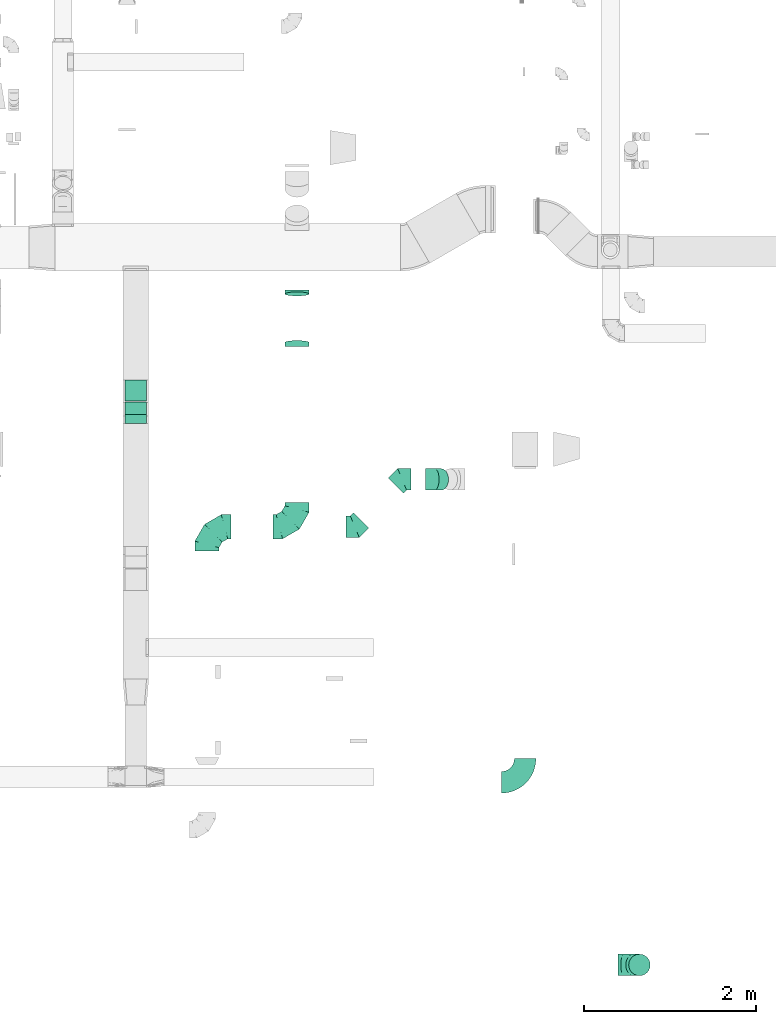
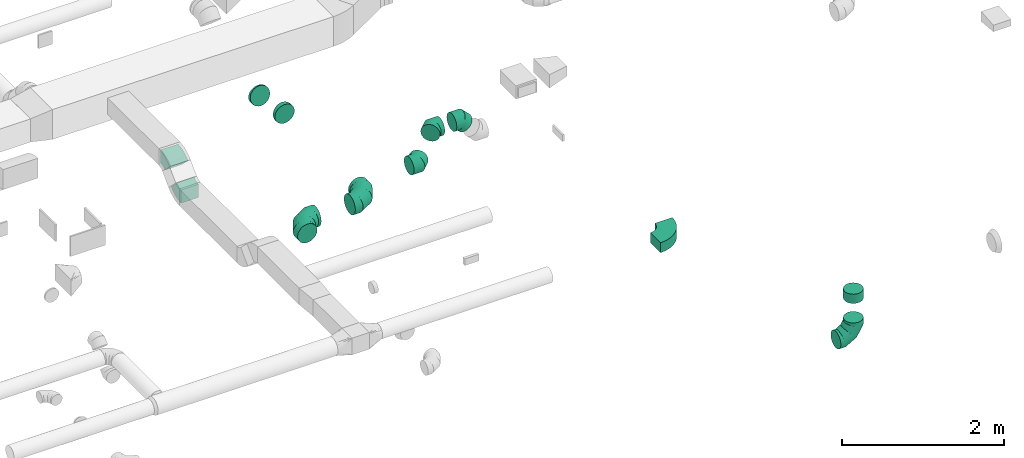
# One storey, part 39 of 62: 12 flow fittings.
"""IFC2X3 building model written with IfcOpenShell, lengths in millimetres."""

import ifcopenshell
import ifcopenshell.guid

model = None  # the IFC model being written
_history = None  # IfcOwnerHistory: only IFC2X3 demands one
_inside = {}  # id of a spatial element -> (the spatial element, [elements in it])
_under = {}  # id of a project, library or spatial element -> (it, [spatial elements below it])
_declared = {}  # id of a project -> (the project, [libraries it declares])
_typed = {}  # id of a type object -> (the type object, [elements of that type])
_made_of = {}  # id of a material, layer set ... -> (it, [elements and type objects made of it])


def new_model(schema):
    """Start an empty IFC model of exactly this schema.

    Asked for "IFC4X3", IfcOpenShell would pick the latest addendum, in which some entities
    have other attributes; the version numbers below select the first issue.
    IFC2X3 requires an IfcOwnerHistory on every rooted entity: one is made here for all.
    """
    global model, _history
    if schema == "IFC4X3":
        model = ifcopenshell.file(schema_version=(4, 3, 0, 0))
    else:
        model = ifcopenshell.file(schema=schema)
    _inside.clear()
    _under.clear()
    _declared.clear()
    _typed.clear()
    _made_of.clear()
    _history = None
    if model.schema == "IFC2X3":
        org = make("IfcOrganization", Name="unknown")
        user = make(
            "IfcPersonAndOrganization",
            ThePerson=make("IfcPerson", FamilyName="unknown"),
            TheOrganization=org,
        )
        app = make(
            "IfcApplication",
            ApplicationDeveloper=org,
            Version="unknown",
            ApplicationFullName="unknown",
            ApplicationIdentifier="unknown",
        )
        _history = make(
            "IfcOwnerHistory",
            OwningUser=user,
            OwningApplication=app,
            ChangeAction="ADDED",
            CreationDate=0,
        )
    return model


def make(cls, **values):
    """One entity of the class cls with the attributes given. An attribute that is None is left unset."""
    return model.create_entity(
        cls, **{name: value for name, value in values.items() if value is not None}
    )


def entity(cls, *values):
    """Any entity or typed value of the class cls, its attributes in the order of the schema. None: left unset."""
    e = model.create_entity(cls)
    for i, value in enumerate(values):
        if value is not None:
            e[i] = value
    return e


def rooted(cls, **values):
    """An entity with a GlobalId (a new one), such as an element, a storey or a relation."""
    return make(cls, GlobalId=ifcopenshell.guid.new(), OwnerHistory=_history, **values)


def si_unit(unit_type, name, prefix=None):
    """IfcSIUnit, for example si_unit("LENGTHUNIT", "METRE", prefix="MILLI")."""
    return make("IfcSIUnit", UnitType=unit_type, Prefix=prefix, Name=name)


def converted_unit(unit_type, name, factor, base, dimensions=None, offset=None):
    """IfcConversionBasedUnit, such as the inch: factor (a typed value) times the base unit."""
    return make(
        "IfcConversionBasedUnit"
        if offset is None
        else "IfcConversionBasedUnitWithOffset",
        ConversionOffset=offset,
        Dimensions=None
        if dimensions is None
        else entity("IfcDimensionalExponents", *dimensions),
        UnitType=unit_type,
        Name=name,
        ConversionFactor=make(
            "IfcMeasureWithUnit", ValueComponent=factor, UnitComponent=base
        ),
    )


def derived_unit(unit_type, elements):
    """IfcDerivedUnit: a product of units, each with its exponent."""
    return make(
        "IfcDerivedUnit",
        Elements=[
            make("IfcDerivedUnitElement", Unit=unit, Exponent=power)
            for unit, power in elements
        ],
        UnitType=unit_type,
    )


def assignment(units):
    """IfcUnitAssignment: the units of a project."""
    return None if units is None else make("IfcUnitAssignment", Units=units)


def point(xyz):
    """IfcCartesianPoint."""
    return None if xyz is None else make("IfcCartesianPoint", Coordinates=xyz)


def direction(xyz):
    """IfcDirection."""
    return None if xyz is None else make("IfcDirection", DirectionRatios=xyz)


def frame(location, z_axis=None, x_axis=None):
    """IfcAxis2Placement3D, a coordinate frame: its origin and axes. An axis left out is left unset."""
    return make(
        "IfcAxis2Placement3D",
        Location=point(location),
        Axis=direction(z_axis),
        RefDirection=direction(x_axis),
    )


def frame_2d(location, x_axis=None):
    """IfcAxis2Placement2D, a coordinate frame in the plane: its origin and x axis."""
    return make(
        "IfcAxis2Placement2D", Location=point(location), RefDirection=direction(x_axis)
    )


def origin():
    """The frame at (0, 0, 0) with its axes left unset."""
    return frame((0.0, 0.0, 0.0))


def place(relative_to, where):
    """IfcLocalPlacement: puts the frame where relative to a parent placement (None: the world)."""
    return make(
        "IfcLocalPlacement", PlacementRelTo=relative_to, RelativePlacement=where
    )


def context(
    kind, dimensions, precision=None, world=None, true_north=None, identifier=None
):
    """IfcGeometricRepresentationContext, for example the 3D "Model" context."""
    return make(
        "IfcGeometricRepresentationContext",
        ContextIdentifier=identifier,
        ContextType=kind,
        CoordinateSpaceDimension=dimensions,
        Precision=precision,
        WorldCoordinateSystem=world,
        TrueNorth=true_north,
    )


def subcontext(parent, identifier, kind, view, scale=None):
    """IfcGeometricRepresentationSubContext, for example "Body" below "Model"."""
    return make(
        "IfcGeometricRepresentationSubContext",
        ContextIdentifier=identifier,
        ContextType=kind,
        ParentContext=parent,
        TargetScale=scale,
        TargetView=view,
    )


def project(units=None, contexts=None):
    """IfcProject with its units and contexts."""
    return rooted(
        "IfcProject",
        Name="project",
        RepresentationContexts=contexts,
        UnitsInContext=assignment(units),
    )


def spatial(cls, under=None, at=None, **own):
    """A site, building, storey or space (cls), placed at a placement, below another one or the project."""
    s = rooted(cls, ObjectPlacement=at, **own)
    if under is not None:
        _under.setdefault(under.id(), (under, []))[1].append(s)
    return s


def polyline(points):
    """IfcPolyline through the points."""
    return make("IfcPolyline", Points=[point(p) for p in points])


def circle_curve(where, radius):
    """IfcCircle in the frame where."""
    return make("IfcCircle", Position=where, Radius=radius)


def parameter(value):
    """IfcParameterValue: where a trimmed curve begins or ends, as a parameter of its basis curve."""
    return model.create_entity("IfcParameterValue", value)


def trimmed(basis, trim1, trim2, sense, master):
    """IfcTrimmedCurve: the piece of a basis curve between two trims."""
    return make(
        "IfcTrimmedCurve",
        BasisCurve=basis,
        Trim1=trim1,
        Trim2=trim2,
        SenseAgreement=sense,
        MasterRepresentation=master,
    )


def segment(curve, same_sense, transition):
    """IfcCompositeCurveSegment."""
    return make(
        "IfcCompositeCurveSegment",
        Transition=transition,
        SameSense=same_sense,
        ParentCurve=curve,
    )


def composite_curve(segments, self_intersect=None):
    """IfcCompositeCurve: segments joined end to end."""
    return make("IfcCompositeCurve", Segments=segments, SelfIntersect=self_intersect)


def outline(outer, holes=None, kind="AREA"):
    """IfcArbitraryClosedProfileDef: a profile drawn as a closed curve; with holes, ...WithVoids."""
    if holes is None:
        return make("IfcArbitraryClosedProfileDef", ProfileType=kind, OuterCurve=outer)
    return make(
        "IfcArbitraryProfileDefWithVoids",
        ProfileType=kind,
        OuterCurve=outer,
        InnerCurves=holes,
    )


def extrude(swept, where, along, depth):
    """IfcExtrudedAreaSolid: the profile swept, set in the frame where, extruded along a direction by depth."""
    return make(
        "IfcExtrudedAreaSolid",
        SweptArea=swept,
        Position=where,
        ExtrudedDirection=direction(along),
        Depth=depth,
    )


def faces_of(points, faces, orient=None, outer=None):
    """IfcFace entities. A face is a list of loops; a loop is a list of indices into points, from 0.

    orient and outer hold one flag for each loop. By default every Orientation is true, the
    first loop of a face is its IfcFaceOuterBound and the others are IfcFaceBound.
    """
    made = []
    for i, loops in enumerate(faces):
        bounds = []
        for j, loop in enumerate(loops):
            is_outer = j == 0 if outer is None else outer[i][j]
            bounds.append(
                make(
                    "IfcFaceOuterBound" if is_outer else "IfcFaceBound",
                    Bound=make("IfcPolyLoop", Polygon=[points[k] for k in loop]),
                    Orientation=True if orient is None else orient[i][j],
                )
            )
        made.append(make("IfcFace", Bounds=bounds))
    return made


def faceted_brep(points, faces, orient=None, outer=None, voids=None):
    """IfcFacetedBrep: a solid bounded by flat faces; with voids (closed shells), ...WithVoids."""
    shared = [point(p) for p in points]
    hull = make("IfcClosedShell", CfsFaces=faces_of(shared, faces, orient, outer))
    if voids is None:
        return make("IfcFacetedBrep", Outer=hull)
    return make(
        "IfcFacetedBrepWithVoids",
        Outer=hull,
        Voids=[
            make(cls, CfsFaces=faces_of(shared, fs, o, b)) for cls, fs, o, b in voids
        ],
    )


def shape(context_of_items, identifier, shape_type, items):
    """IfcShapeRepresentation: the items that make up one representation, for example the "Body"."""
    return make(
        "IfcShapeRepresentation",
        ContextOfItems=context_of_items,
        RepresentationIdentifier=identifier,
        RepresentationType=shape_type,
        Items=items,
    )


def source(mapping_origin, context_of_items, identifier, shape_type, items):
    """IfcRepresentationMap: a shape defined once, which mapped items show again and again."""
    return make(
        "IfcRepresentationMap",
        MappingOrigin=mapping_origin,
        MappedRepresentation=shape(context_of_items, identifier, shape_type, items),
    )


def transform(
    local_origin,
    x_axis=None,
    y_axis=None,
    z_axis=None,
    scale=None,
    scale2=None,
    scale3=None,
    uniform=True,
):
    """IfcCartesianTransformationOperator3D, or its non-uniform kind. x_axis, y_axis, z_axis: its Axis1, 2, 3."""
    if uniform:
        return make(
            "IfcCartesianTransformationOperator3D",
            Axis1=direction(x_axis),
            Axis2=direction(y_axis),
            LocalOrigin=point(local_origin),
            Scale=scale,
            Axis3=direction(z_axis),
        )
    return make(
        "IfcCartesianTransformationOperator3DnonUniform",
        Axis1=direction(x_axis),
        Axis2=direction(y_axis),
        LocalOrigin=point(local_origin),
        Scale=scale,
        Axis3=direction(z_axis),
        Scale2=scale2,
        Scale3=scale3,
    )


def mapped(mapping_source, mapping_target):
    """IfcMappedItem: shows the shape of a source again, moved by a transform."""
    return make(
        "IfcMappedItem", MappingSource=mapping_source, MappingTarget=mapping_target
    )


def material(Name=None, Category=None):
    """IfcMaterial."""
    return make("IfcMaterial", Name=Name, Category=Category)


def made_of(thing, what):
    """Note that an element or type object is made of a material, layer set ...; save() writes the relation."""
    if what is not None:
        _made_of.setdefault(what.id(), (what, []))[1].append(thing)
    return thing


def type_object(cls, material=None, **own):
    """A type object (cls), such as IfcWallType, which elements share."""
    return made_of(rooted(cls, **own), material)


def type_shapes(of_type, sources):
    """Give a type object the sources (RepresentationMaps) that its elements show as mapped items."""
    of_type.RepresentationMaps = sources


def element(
    cls,
    number,
    at=None,
    inside=None,
    cuts=None,
    type_object=None,
    material=None,
    context=None,
    identifier="Body",
    shape_type=None,
    held_by="IfcProductDefinitionShape",
    body=None,
    shapes=None,
    **own,
):
    """One element of the class cls, such as IfcWall. Its Tag is "e" and its number.

    at: its placement. inside: the storey or other place that contains it. cuts: it is an
    opening in that element (IfcRelVoidsElement). A single representation is given by context,
    identifier, shape_type and body (its items); several are given by shapes. held_by: the class
    of the entity that holds the representations. save() writes the other relations.
    """
    e = rooted(cls, Tag="e%d" % number, ObjectPlacement=at, **own)
    if body is not None:
        shapes = [shape(context, identifier, shape_type, body)]
    if shapes is not None:
        e.Representation = make(held_by, Representations=shapes)
    if inside is not None:
        _inside.setdefault(inside.id(), (inside, []))[1].append(e)
    if cuts is not None:
        rooted(
            "IfcRelVoidsElement", RelatingBuildingElement=cuts, RelatedOpeningElement=e
        )
    if type_object is not None:
        _typed.setdefault(type_object.id(), (type_object, []))[1].append(e)
    return made_of(e, material)


def aggregate(whole, parts):
    """IfcRelAggregates: a whole, such as a stair, and the parts it consists of."""
    return rooted("IfcRelAggregates", RelatingObject=whole, RelatedObjects=parts)


def save(model, path):
    """Write the relations noted so far, then the file.

    IfcRelAggregates (storeys below a building ...), IfcRelContainedInSpatialStructure (elements
    in a storey), IfcRelDefinesByType, IfcRelAssociatesMaterial and IfcRelDeclares: one each for
    every whole, place, type object, material and project.
    """
    for whole, parts in _under.values():
        aggregate(whole, parts)
    for where, things in _inside.values():
        rooted(
            "IfcRelContainedInSpatialStructure",
            RelatedElements=things,
            RelatingStructure=where,
        )
    for kind, things in _typed.values():
        rooted("IfcRelDefinesByType", RelatedObjects=things, RelatingType=kind)
    for what, things in _made_of.values():
        rooted("IfcRelAssociatesMaterial", RelatedObjects=things, RelatingMaterial=what)
    for by, libraries in _declared.values():
        rooted("IfcRelDeclares", RelatingContext=by, RelatedDefinitions=libraries)
    model.write(path)


model = new_model("IFC2X3")

# Units and contexts
model_context = context("Model", 3, precision=0.01, world=origin(), true_north=direction((6.12303176911189e-17, 1.0)))
body_context = subcontext(model_context, "Body", "Model", "MODEL_VIEW")
ifc_project = project(units=[si_unit("LENGTHUNIT", "METRE", prefix="MILLI"), si_unit("AREAUNIT", "SQUARE_METRE"), si_unit("VOLUMEUNIT", "CUBIC_METRE"), converted_unit("PLANEANGLEUNIT", "DEGREE", entity("IfcRatioMeasure", 0.0174532925199433), si_unit("PLANEANGLEUNIT", "RADIAN"), dimensions=[0, 0, 0, 0, 0, 0, 0]), si_unit("MASSUNIT", "GRAM", prefix="KILO"), derived_unit("MASSDENSITYUNIT", [(si_unit("MASSUNIT", "GRAM", prefix="KILO"), 1), (si_unit("LENGTHUNIT", "METRE"), -3)]), derived_unit("MOMENTOFINERTIAUNIT", [(si_unit("LENGTHUNIT", "METRE"), 4)]), si_unit("TIMEUNIT", "SECOND"), si_unit("FREQUENCYUNIT", "HERTZ"), si_unit("THERMODYNAMICTEMPERATUREUNIT", "DEGREE_CELSIUS"), derived_unit("THERMALTRANSMITTANCEUNIT", [(si_unit("MASSUNIT", "GRAM", prefix="KILO"), 1), (si_unit("THERMODYNAMICTEMPERATUREUNIT", "KELVIN"), -1), (si_unit("TIMEUNIT", "SECOND"), -3)]), derived_unit("VOLUMETRICFLOWRATEUNIT", [(si_unit("LENGTHUNIT", "METRE"), 3), (si_unit("TIMEUNIT", "SECOND"), -1)]), derived_unit("MASSFLOWRATEUNIT", [(si_unit("MASSUNIT", "GRAM", prefix="KILO"), 1), (si_unit("TIMEUNIT", "SECOND"), -1)]), derived_unit("ROTATIONALFREQUENCYUNIT", [(si_unit("TIMEUNIT", "SECOND"), -1)]), si_unit("ELECTRICCURRENTUNIT", "AMPERE"), si_unit("ELECTRICVOLTAGEUNIT", "VOLT"), si_unit("POWERUNIT", "WATT"), si_unit("FORCEUNIT", "NEWTON", prefix="KILO"), si_unit("ILLUMINANCEUNIT", "LUX"), si_unit("LUMINOUSFLUXUNIT", "LUMEN"), si_unit("LUMINOUSINTENSITYUNIT", "CANDELA"), derived_unit("USERDEFINED", [(si_unit("MASSUNIT", "GRAM", prefix="KILO"), -1), (si_unit("LENGTHUNIT", "METRE"), -2), (si_unit("TIMEUNIT", "SECOND"), 3), (si_unit("LUMINOUSFLUXUNIT", "LUMEN"), 1)]), derived_unit("LINEARVELOCITYUNIT", [(si_unit("LENGTHUNIT", "METRE"), 1), (si_unit("TIMEUNIT", "SECOND"), -1)]), si_unit("PRESSUREUNIT", "PASCAL"), derived_unit("USERDEFINED", [(si_unit("LENGTHUNIT", "METRE"), -2), (si_unit("MASSUNIT", "GRAM", prefix="KILO"), 1), (si_unit("TIMEUNIT", "SECOND"), -2)]), derived_unit("LINEARFORCEUNIT", [(si_unit("MASSUNIT", "GRAM", prefix="KILO"), 1), (si_unit("LENGTHUNIT", "METRE"), 1), (si_unit("TIMEUNIT", "SECOND"), -2), (si_unit("LENGTHUNIT", "METRE"), -1)]), derived_unit("PLANARFORCEUNIT", [(si_unit("MASSUNIT", "GRAM", prefix="KILO"), 1), (si_unit("LENGTHUNIT", "METRE"), 1), (si_unit("TIMEUNIT", "SECOND"), -2), (si_unit("LENGTHUNIT", "METRE"), -2)])], contexts=[model_context])

# Site, building, storey
site_placement = place(None, origin())
site = spatial("IfcSite", under=ifc_project, at=site_placement, CompositionType="ELEMENT")
building_placement = place(site_placement, origin())
building = spatial("IfcBuilding", under=site, at=building_placement, CompositionType="ELEMENT")
storey_placement = place(building_placement, frame((0.0, 0.0, 24000.0)))
storey = spatial("IfcBuildingStorey", under=building, at=storey_placement, CompositionType="ELEMENT", Elevation=24000.0)

# Flow fittings
ifc_material = material()
duct_fitting_type_1 = type_object("IfcDuctFittingType", PredefinedType="NOTDEFINED", material=ifc_material)
shared_shape_1 = source(origin(), body_context, "Body", "Brep", [
    faceted_brep([(-250.0, 0.0, -125.0), (-250.0, -32.35, -120.74), (-250.0, -62.5, -108.25), (-250.0, -88.39, -88.39), (-250.0, -108.25, -62.5), (-250.0, -120.74, -32.35), (-250.0, -125.0, 0.0), (-250.0, -120.74, 32.35), (-250.0, -108.25, 62.5), (-250.0, -88.39, 88.39), (-250.0, -62.5, 108.25), (-250.0, -32.35, 120.74), (-250.0, 0.0, 125.0), (-250.0, 32.35, 120.74), (-250.0, 62.5, 108.25), (-250.0, 88.39, 88.39), (-250.0, 108.25, 62.5), (-250.0, 120.74, 32.35), (-250.0, 125.0, 0.0), (-250.0, 120.74, -32.35), (-250.0, 108.25, -62.5), (-250.0, 88.39, -88.39), (-250.0, 62.5, -108.25), (-250.0, 32.35, -120.74), (-191.68, 32.35, 120.74), (-199.76, 62.5, 108.25), (-183.01, 0.0, 125.0), (-206.7, 88.39, 88.39), (-215.37, 120.74, 32.35), (-216.51, 125.0, 0.0), (-212.02, 108.25, 62.5), (-212.02, 108.25, -62.5), (-206.7, 88.39, -88.39), (-215.37, 120.74, -32.35), (-191.68, 32.35, -120.74), (-183.01, 0.0, -125.0), (-199.76, 62.5, -108.25), (-174.34, -32.35, -120.74), (-166.27, -62.5, -108.25), (-159.33, -88.39, -88.39), (-154.01, -108.25, -62.5), (-150.66, -120.74, -32.35), (-149.52, -125.0, 0.0), (-150.66, -120.74, 32.35), (-154.01, -108.25, 62.5), (-159.33, -88.39, 88.39), (-166.27, -62.5, 108.25), (-174.34, -32.35, 120.74), (-90.67, 90.67, 120.74), (-112.74, 112.74, 108.25), (-66.99, 66.99, 125.0), (-131.69, 131.69, 88.39), (-146.23, 146.23, 62.5), (-155.38, 155.38, 32.35), (-158.49, 158.49, 0.0), (-155.38, 155.38, -32.35), (-146.23, 146.23, -62.5), (-131.69, 131.69, -88.39), (-90.67, 90.67, -120.74), (-66.99, 66.99, -125.0), (-112.74, 112.74, -108.25), (-43.3, 43.3, -120.74), (-21.23, 21.23, -108.25), (-2.28, 2.28, -88.39), (12.26, -12.26, -62.5), (21.4, -21.4, -32.35), (24.52, -24.52, 0.0), (21.4, -21.4, 32.35), (12.26, -12.26, 62.5), (-2.28, 2.28, 88.39), (-21.23, 21.23, 108.25), (-43.3, 43.3, 120.74), (-32.35, 191.68, 120.74), (-62.5, 199.76, 108.25), (0.0, 183.01, 125.0), (-88.39, 206.7, 88.39), (-108.25, 212.02, 62.5), (-120.74, 215.37, 32.35), (-125.0, 216.51, 0.0), (-120.74, 215.37, -32.35), (-108.25, 212.02, -62.5), (-88.39, 206.7, -88.39), (-32.35, 191.68, -120.74), (0.0, 183.01, -125.0), (-62.5, 199.76, -108.25), (32.35, 174.34, -120.74), (62.5, 166.27, -108.25), (88.39, 159.33, -88.39), (108.25, 154.01, -62.5), (120.74, 150.66, -32.35), (125.0, 149.52, 0.0), (120.74, 150.66, 32.35), (108.25, 154.01, 62.5), (88.39, 159.33, 88.39), (62.5, 166.27, 108.25), (32.35, 174.34, 120.74), (-32.35, 250.0, -120.74), (-62.5, 250.0, -108.25), (-88.39, 250.0, -88.39), (-108.25, 250.0, -62.5), (-120.74, 250.0, -32.35), (-125.0, 250.0, 0.0), (-120.74, 250.0, 32.35), (-108.25, 250.0, 62.5), (-88.39, 250.0, 88.39), (-62.5, 250.0, 108.25), (-32.35, 250.0, 120.74), (0.0, 250.0, 125.0), (32.35, 250.0, 120.74), (62.5, 250.0, 108.25), (88.39, 250.0, 88.39), (108.25, 250.0, 62.5), (120.74, 250.0, 32.35), (125.0, 250.0, 0.0), (120.74, 250.0, -32.35), (108.25, 250.0, -62.5), (88.39, 250.0, -88.39), (62.5, 250.0, -108.25), (32.35, 250.0, -120.74), (0.0, 250.0, -125.0)], [[[0, 1, 2, 3, 4, 5, 6, 7, 8, 9, 10, 11, 12, 13, 14, 15, 16, 17, 18, 19, 20, 21, 22, 23]], [[24, 25, 14, 13]], [[26, 24, 13, 12]], [[14, 25, 27, 15]], [[28, 29, 18, 17]], [[30, 28, 17, 16]], [[15, 27, 30, 16]], [[20, 31, 32, 21]], [[33, 31, 20, 19]], [[18, 29, 33, 19]], [[34, 35, 0, 23]], [[36, 34, 23, 22]], [[21, 32, 36, 22]], [[1, 0, 35, 37]], [[2, 1, 37, 38]], [[38, 39, 3, 2]], [[5, 4, 40, 41]], [[6, 5, 41, 42]], [[39, 40, 4, 3]], [[6, 42, 43, 7]], [[7, 43, 44, 8]], [[8, 44, 45, 9]], [[9, 45, 46, 10]], [[10, 46, 47, 11]], [[26, 12, 11, 47]], [[48, 49, 25, 24]], [[50, 48, 24, 26]], [[27, 25, 49, 51]], [[52, 53, 28, 30]], [[51, 52, 30, 27]], [[29, 28, 53, 54]], [[55, 56, 31, 33]], [[54, 55, 33, 29]], [[32, 31, 56, 57]], [[58, 59, 35, 34]], [[60, 58, 34, 36]], [[57, 60, 36, 32]], [[37, 35, 59, 61]], [[38, 37, 61, 62]], [[39, 38, 62, 63]], [[41, 40, 64, 65]], [[42, 41, 65, 66]], [[63, 64, 40, 39]], [[43, 42, 66, 67]], [[44, 43, 67, 68]], [[68, 69, 45, 44]], [[46, 45, 69, 70]], [[47, 46, 70, 71]], [[26, 47, 71, 50]], [[72, 73, 49, 48]], [[74, 72, 48, 50]], [[51, 49, 73, 75]], [[76, 77, 53, 52]], [[75, 76, 52, 51]], [[54, 53, 77, 78]], [[79, 80, 56, 55]], [[78, 79, 55, 54]], [[57, 56, 80, 81]], [[82, 83, 59, 58]], [[84, 82, 58, 60]], [[81, 84, 60, 57]], [[61, 59, 83, 85]], [[62, 61, 85, 86]], [[63, 62, 86, 87]], [[65, 64, 88, 89]], [[66, 65, 89, 90]], [[87, 88, 64, 63]], [[67, 66, 90, 91]], [[68, 67, 91, 92]], [[92, 93, 69, 68]], [[70, 69, 93, 94]], [[71, 70, 94, 95]], [[50, 71, 95, 74]], [[96, 97, 98, 99, 100, 101, 102, 103, 104, 105, 106, 107, 108, 109, 110, 111, 112, 113, 114, 115, 116, 117, 118, 119]], [[72, 74, 107, 106]], [[73, 72, 106, 105]], [[75, 73, 105, 104]], [[77, 76, 103, 102]], [[78, 77, 102, 101]], [[75, 104, 103, 76]], [[78, 101, 100, 79]], [[79, 100, 99, 80]], [[80, 99, 98, 81]], [[84, 97, 96, 82]], [[82, 96, 119, 83]], [[84, 81, 98, 97]], [[83, 119, 118, 85]], [[85, 118, 117, 86]], [[116, 87, 86, 117]], [[88, 115, 114, 89]], [[89, 114, 113, 90]], [[115, 88, 87, 116]], [[91, 90, 113, 112]], [[92, 91, 112, 111]], [[111, 110, 93, 92]], [[95, 94, 109, 108]], [[74, 95, 108, 107]], [[110, 109, 94, 93]]]),
])
type_shapes(duct_fitting_type_1, [shared_shape_1])
flow_fitting_1_placement = place(storey_placement, frame((61027.3, 593.17, 2900.0), z_axis=(0.0, -1.0, 0.0), x_axis=(1.0, 0.0, 0.0)))
element("IfcFlowFitting", 1, at=flow_fitting_1_placement, inside=storey, type_object=duct_fitting_type_1, material=ifc_material, context=body_context, shape_type="MappedRepresentation", body=[
    mapped(shared_shape_1, transform((0.0, 0.0, 0.0), scale=1.0)),
])
duct_fitting_type_2 = type_object("IfcDuctFittingType", PredefinedType="NOTDEFINED", material=ifc_material)
shared_shape_2 = source(origin(), body_context, "Body", "Brep", [
    faceted_brep([(-103.55, 0.0, -125.0), (-103.55, -32.35, -120.74), (-103.55, -62.5, -108.25), (-103.55, -88.39, -88.39), (-103.55, -108.25, -62.5), (-103.55, -120.74, -32.35), (-103.55, -125.0, 0.0), (-103.55, -120.74, 32.35), (-103.55, -108.25, 62.5), (-103.55, -88.39, 88.39), (-103.55, -62.5, 108.25), (-103.55, -32.35, 120.74), (-103.55, 0.0, 125.0), (-103.55, 32.35, 120.74), (-103.55, 62.5, 108.25), (-103.55, 88.39, 88.39), (-103.55, 108.25, 62.5), (-103.55, 120.74, 32.35), (-103.55, 125.0, 0.0), (-103.55, 120.74, -32.35), (-103.55, 108.25, -62.5), (-103.55, 88.39, -88.39), (-103.55, 62.5, -108.25), (-103.55, 32.35, -120.74), (-13.4, 32.35, 120.74), (-25.89, 62.5, 108.25), (0.0, 0.0, 125.0), (-36.61, 88.39, 88.39), (-44.84, 108.25, 62.5), (-50.01, 120.74, 32.35), (-51.78, 125.0, 0.0), (-50.01, 120.74, -32.35), (-44.84, 108.25, -62.5), (-36.61, 88.39, -88.39), (-13.4, 32.35, -120.74), (0.0, 0.0, -125.0), (-25.89, 62.5, -108.25), (13.4, -32.35, -120.74), (25.89, -62.5, -108.25), (36.61, -88.39, -88.39), (44.84, -108.25, -62.5), (50.01, -120.74, -32.35), (51.78, -125.0, 0.0), (50.01, -120.74, 32.35), (44.84, -108.25, 62.5), (36.61, -88.39, 88.39), (25.89, -62.5, 108.25), (13.4, -32.35, 120.74), (73.22, 73.22, 125.0), (50.35, 96.1, 120.74), (29.03, 117.42, 108.25), (10.72, 135.72, 88.39), (-3.32, 149.77, 62.5), (-12.15, 158.6, 32.35), (-15.17, 161.61, 0.0), (-12.15, 158.6, -32.35), (-3.32, 149.77, -62.5), (10.72, 135.72, -88.39), (29.03, 117.42, -108.25), (50.35, 96.1, -120.74), (73.22, 73.22, -125.0), (96.1, 50.35, -120.74), (117.42, 29.03, -108.25), (135.72, 10.72, -88.39), (149.77, -3.32, -62.5), (158.6, -12.15, -32.35), (161.61, -15.17, 0.0), (158.6, -12.15, 32.35), (149.77, -3.32, 62.5), (135.72, 10.72, 88.39), (117.42, 29.03, 108.25), (96.1, 50.35, 120.74)], [[[0, 1, 2, 3, 4, 5, 6, 7, 8, 9, 10, 11, 12, 13, 14, 15, 16, 17, 18, 19, 20, 21, 22, 23]], [[24, 25, 14, 13]], [[26, 24, 13, 12]], [[14, 25, 27, 15]], [[28, 29, 17, 16]], [[28, 16, 15, 27]], [[30, 18, 17, 29]], [[31, 32, 20, 19]], [[30, 31, 19, 18]], [[32, 33, 21, 20]], [[34, 35, 0, 23]], [[36, 34, 23, 22]], [[33, 36, 22, 21]], [[1, 0, 35, 37]], [[2, 1, 37, 38]], [[38, 39, 3, 2]], [[5, 4, 40, 41]], [[6, 5, 41, 42]], [[39, 40, 4, 3]], [[6, 42, 43, 7]], [[7, 43, 44, 8]], [[8, 44, 45, 9]], [[9, 45, 46, 10]], [[10, 46, 47, 11]], [[26, 12, 11, 47]], [[24, 26, 48, 49]], [[25, 24, 49, 50]], [[27, 25, 50, 51]], [[29, 28, 52, 53]], [[30, 29, 53, 54]], [[51, 52, 28, 27]], [[30, 54, 55, 31]], [[31, 55, 56, 32]], [[57, 33, 32, 56]], [[36, 58, 59, 34]], [[34, 59, 60, 35]], [[58, 36, 33, 57]], [[35, 60, 61, 37]], [[37, 61, 62, 38]], [[63, 39, 38, 62]], [[40, 64, 65, 41]], [[41, 65, 66, 42]], [[64, 40, 39, 63]], [[43, 42, 66, 67]], [[44, 43, 67, 68]], [[68, 69, 45, 44]], [[47, 46, 70, 71]], [[26, 47, 71, 48]], [[69, 70, 46, 45]], [[59, 58, 57, 56, 55, 54, 53, 52, 51, 50, 49, 48, 71, 70, 69, 68, 67, 66, 65, 64, 63, 62, 61, 60]]]),
])
type_shapes(duct_fitting_type_2, [shared_shape_2])
flow_fitting_2_placement = place(storey_placement, frame((58649.48, 6229.86, 3550.0), z_axis=(0.0, -1.0, 0.0), x_axis=(-0.707106792500326, 0.0, 0.707106769872769)))
element("IfcFlowFitting", 2, at=flow_fitting_2_placement, inside=storey, type_object=duct_fitting_type_2, material=ifc_material, context=body_context, shape_type="MappedRepresentation", body=[
    mapped(shared_shape_2, transform((0.0, 0.0, 0.0), scale=1.0)),
])
duct_fitting_type_3 = type_object("IfcDuctFittingType", PredefinedType="NOTDEFINED", material=ifc_material)
type_shapes(duct_fitting_type_3, [shared_shape_2])
flow_fitting_3_placement = place(storey_placement, frame((58271.96, 6229.86, 3550.0), z_axis=(0.0, 0.0, 1.0), x_axis=(-1.0, 0.0, 0.0)))
element("IfcFlowFitting", 3, at=flow_fitting_3_placement, inside=storey, type_object=duct_fitting_type_3, material=ifc_material, context=body_context, shape_type="MappedRepresentation", body=[
    mapped(shared_shape_2, transform((0.0, 0.0, 0.0), scale=1.0)),
])
flow_fitting_4_placement = place(storey_placement, frame((57722.39, 5680.28, 3550.0)))
element("IfcFlowFitting", 4, at=flow_fitting_4_placement, inside=storey, type_object=duct_fitting_type_3, material=ifc_material, context=body_context, shape_type="MappedRepresentation", body=[
    mapped(shared_shape_2, transform((0.0, 0.0, 0.0), scale=1.0)),
])
duct_fitting_type_4 = type_object("IfcDuctFittingType", PredefinedType="NOTDEFINED", material=ifc_material)
shared_shape_3 = source(origin(), body_context, "Body", "Brep", [
    faceted_brep([(20.0, 0.0, -125.0), (20.0, 32.35, -120.74), (20.0, 62.5, -108.25), (20.0, 88.39, -88.39), (20.0, 108.25, -62.5), (20.0, 120.74, -32.35), (20.0, 125.0, 0.0), (20.0, 120.74, 32.35), (20.0, 108.25, 62.5), (20.0, 88.39, 88.39), (20.0, 62.5, 108.25), (20.0, 32.35, 120.74), (20.0, 0.0, 125.0), (20.0, -32.35, 120.74), (20.0, -62.5, 108.25), (20.0, -88.39, 88.39), (20.0, -108.25, 62.5), (20.0, -120.74, 32.35), (20.0, -125.0, 0.0), (20.0, -120.74, -32.35), (20.0, -108.25, -62.5), (20.0, -88.39, -88.39), (20.0, -62.5, -108.25), (20.0, -32.35, -120.74), (0.0, 0.0, 125.0), (-118.9, 0.0, 125.0), (-118.9, -32.35, 120.74), (0.0, -32.35, 120.74), (-118.9, -62.5, 108.25), (0.0, -62.5, 108.25), (0.0, -88.39, 88.39), (-118.9, -88.39, 88.39), (0.0, -108.25, 62.5), (-118.9, -108.25, 62.5), (-118.9, -120.74, 32.35), (0.0, -120.74, 32.35), (-118.9, -125.0, 0.0), (0.0, -125.0, 0.0), (-118.9, -120.74, -32.35), (0.0, -120.74, -32.35), (-118.9, -108.25, -62.5), (0.0, -108.25, -62.5), (0.0, -88.39, -88.39), (-118.9, -88.39, -88.39), (0.0, -62.5, -108.25), (-118.9, -62.5, -108.25), (-118.9, -32.35, -120.74), (0.0, -32.35, -120.74), (-118.9, 0.0, -125.0), (0.0, 0.0, -125.0), (-118.9, 32.35, -120.74), (0.0, 32.35, -120.74), (-118.9, 62.5, -108.25), (0.0, 62.5, -108.25), (0.0, 88.39, -88.39), (-118.9, 88.39, -88.39), (0.0, 108.25, -62.5), (-118.9, 108.25, -62.5), (-118.9, 120.74, -32.35), (0.0, 120.74, -32.35), (-118.9, 125.0, 0.0), (0.0, 125.0, 0.0), (-118.9, 120.74, 32.35), (0.0, 120.74, 32.35), (-118.9, 108.25, 62.5), (0.0, 108.25, 62.5), (0.0, 88.39, 88.39), (-118.9, 88.39, 88.39), (0.0, 62.5, 108.25), (-118.9, 62.5, 108.25), (-118.9, 32.35, 120.74), (0.0, 32.35, 120.74)], [[[0, 1, 2, 3, 4, 5, 6, 7, 8, 9, 10, 11, 12, 13, 14, 15, 16, 17, 18, 19, 20, 21, 22, 23]], [[13, 12, 24, 25, 26, 27]], [[14, 13, 27, 26, 28, 29]], [[30, 15, 14, 29, 28, 31]], [[17, 16, 32, 33, 34, 35]], [[18, 17, 35, 34, 36, 37]], [[32, 16, 15, 30, 31, 33]], [[19, 18, 37, 36, 38, 39]], [[20, 19, 39, 38, 40, 41]], [[42, 21, 20, 41, 40, 43]], [[23, 22, 44, 45, 46, 47]], [[0, 23, 47, 46, 48, 49]], [[44, 22, 21, 42, 43, 45]], [[1, 0, 49, 48, 50, 51]], [[2, 1, 51, 50, 52, 53]], [[54, 3, 2, 53, 52, 55]], [[5, 4, 56, 57, 58, 59]], [[6, 5, 59, 58, 60, 61]], [[56, 4, 3, 54, 55, 57]], [[7, 6, 61, 60, 62, 63]], [[8, 7, 63, 62, 64, 65]], [[66, 9, 8, 65, 64, 67]], [[11, 10, 68, 69, 70, 71]], [[12, 11, 71, 70, 25, 24]], [[68, 10, 9, 66, 67, 69]], [[46, 45, 43, 40, 38, 36, 34, 33, 31, 28, 26, 25, 70, 69, 67, 64, 62, 60, 58, 57, 55, 52, 50, 48]]]),
])
type_shapes(duct_fitting_type_4, [shared_shape_3])
flow_fitting_5_placement = place(storey_placement, frame((61027.3, 593.17, 3465.0), z_axis=(-1.0, 0.0, 0.0), x_axis=(0.0, 0.0, -1.0)))
element("IfcFlowFitting", 5, at=flow_fitting_5_placement, inside=storey, type_object=duct_fitting_type_4, material=ifc_material, context=body_context, shape_type="MappedRepresentation", body=[
    mapped(shared_shape_3, transform((0.0, 0.0, 0.0), scale=1.0)),
])
duct_fitting_type_5 = type_object("IfcDuctFittingType", PredefinedType="NOTDEFINED", material=ifc_material)
shared_shape_4 = source(origin(), body_context, "Body", "Brep", [
    faceted_brep([(-280.0, 0.0, -140.0), (-280.0, -36.23, -135.23), (-280.0, -70.0, -121.24), (-280.0, -98.99, -98.99), (-280.0, -121.24, -70.0), (-280.0, -135.23, -36.23), (-280.0, -140.0, 0.0), (-280.0, -135.23, 36.23), (-280.0, -121.24, 70.0), (-280.0, -98.99, 98.99), (-280.0, -70.0, 121.24), (-280.0, -36.23, 135.23), (-280.0, 0.0, 140.0), (-280.0, 36.23, 135.23), (-280.0, 70.0, 121.24), (-280.0, 98.99, 98.99), (-280.0, 121.24, 70.0), (-280.0, 135.23, 36.23), (-280.0, 140.0, 0.0), (-280.0, 135.23, -36.23), (-280.0, 121.24, -70.0), (-280.0, 98.99, -98.99), (-280.0, 70.0, -121.24), (-280.0, 36.23, -135.23), (-214.68, 36.23, 135.23), (-223.73, 70.0, 121.24), (-204.97, 0.0, 140.0), (-231.5, 98.99, 98.99), (-241.21, 135.23, 36.23), (-242.49, 140.0, 0.0), (-237.46, 121.24, 70.0), (-237.46, 121.24, -70.0), (-231.5, 98.99, -98.99), (-241.21, 135.23, -36.23), (-214.68, 36.23, -135.23), (-204.97, 0.0, -140.0), (-223.73, 70.0, -121.24), (-195.27, -36.23, -135.23), (-186.22, -70.0, -121.24), (-178.45, -98.99, -98.99), (-172.49, -121.24, -70.0), (-168.74, -135.23, -36.23), (-167.46, -140.0, 0.0), (-168.74, -135.23, 36.23), (-172.49, -121.24, 70.0), (-178.45, -98.99, 98.99), (-186.22, -70.0, 121.24), (-195.27, -36.23, 135.23), (-101.55, 101.55, 135.23), (-126.27, 126.27, 121.24), (-75.03, 75.03, 140.0), (-147.5, 147.5, 98.99), (-163.78, 163.78, 70.0), (-174.02, 174.02, 36.23), (-177.51, 177.51, 0.0), (-174.02, 174.02, -36.23), (-163.78, 163.78, -70.0), (-147.5, 147.5, -98.99), (-101.55, 101.55, -135.23), (-75.03, 75.03, -140.0), (-126.27, 126.27, -121.24), (-48.5, 48.5, -135.23), (-23.78, 23.78, -121.24), (-2.56, 2.56, -98.99), (13.73, -13.73, -70.0), (23.97, -23.97, -36.23), (27.46, -27.46, 0.0), (23.97, -23.97, 36.23), (13.73, -13.73, 70.0), (-2.56, 2.56, 98.99), (-23.78, 23.78, 121.24), (-48.5, 48.5, 135.23), (-36.23, 214.68, 135.23), (-70.0, 223.73, 121.24), (0.0, 204.97, 140.0), (-98.99, 231.5, 98.99), (-121.24, 237.46, 70.0), (-135.23, 241.21, 36.23), (-140.0, 242.49, 0.0), (-135.23, 241.21, -36.23), (-121.24, 237.46, -70.0), (-98.99, 231.5, -98.99), (-36.23, 214.68, -135.23), (0.0, 204.97, -140.0), (-70.0, 223.73, -121.24), (36.23, 195.27, -135.23), (70.0, 186.22, -121.24), (98.99, 178.45, -98.99), (121.24, 172.49, -70.0), (135.23, 168.74, -36.23), (140.0, 167.46, 0.0), (135.23, 168.74, 36.23), (121.24, 172.49, 70.0), (98.99, 178.45, 98.99), (70.0, 186.22, 121.24), (36.23, 195.27, 135.23), (-36.23, 280.0, -135.23), (-70.0, 280.0, -121.24), (-98.99, 280.0, -98.99), (-121.24, 280.0, -70.0), (-135.23, 280.0, -36.23), (-140.0, 280.0, 0.0), (-135.23, 280.0, 36.23), (-121.24, 280.0, 70.0), (-98.99, 280.0, 98.99), (-70.0, 280.0, 121.24), (-36.23, 280.0, 135.23), (0.0, 280.0, 140.0), (36.23, 280.0, 135.23), (70.0, 280.0, 121.24), (98.99, 280.0, 98.99), (121.24, 280.0, 70.0), (135.23, 280.0, 36.23), (140.0, 280.0, 0.0), (135.23, 280.0, -36.23), (121.24, 280.0, -70.0), (98.99, 280.0, -98.99), (70.0, 280.0, -121.24), (36.23, 280.0, -135.23), (0.0, 280.0, -140.0)], [[[0, 1, 2, 3, 4, 5, 6, 7, 8, 9, 10, 11, 12, 13, 14, 15, 16, 17, 18, 19, 20, 21, 22, 23]], [[24, 25, 14, 13]], [[26, 24, 13, 12]], [[14, 25, 27, 15]], [[28, 29, 18, 17]], [[30, 28, 17, 16]], [[15, 27, 30, 16]], [[20, 31, 32, 21]], [[33, 31, 20, 19]], [[18, 29, 33, 19]], [[34, 35, 0, 23]], [[36, 34, 23, 22]], [[32, 36, 22, 21]], [[1, 0, 35, 37]], [[2, 1, 37, 38]], [[38, 39, 3, 2]], [[5, 4, 40, 41]], [[6, 5, 41, 42]], [[39, 40, 4, 3]], [[6, 42, 43, 7]], [[7, 43, 44, 8]], [[8, 44, 45, 9]], [[9, 45, 46, 10]], [[10, 46, 47, 11]], [[26, 12, 11, 47]], [[48, 49, 25, 24]], [[50, 48, 24, 26]], [[27, 25, 49, 51]], [[52, 53, 28, 30]], [[51, 52, 30, 27]], [[29, 28, 53, 54]], [[55, 56, 31, 33]], [[54, 55, 33, 29]], [[32, 31, 56, 57]], [[58, 59, 35, 34]], [[60, 58, 34, 36]], [[57, 60, 36, 32]], [[37, 35, 59, 61]], [[38, 37, 61, 62]], [[39, 38, 62, 63]], [[41, 40, 64, 65]], [[42, 41, 65, 66]], [[63, 64, 40, 39]], [[43, 42, 66, 67]], [[44, 43, 67, 68]], [[68, 69, 45, 44]], [[46, 45, 69, 70]], [[47, 46, 70, 71]], [[26, 47, 71, 50]], [[72, 73, 49, 48]], [[74, 72, 48, 50]], [[51, 49, 73, 75]], [[76, 77, 53, 52]], [[75, 76, 52, 51]], [[54, 53, 77, 78]], [[79, 80, 56, 55]], [[78, 79, 55, 54]], [[57, 56, 80, 81]], [[82, 83, 59, 58]], [[84, 82, 58, 60]], [[81, 84, 60, 57]], [[61, 59, 83, 85]], [[62, 61, 85, 86]], [[63, 62, 86, 87]], [[65, 64, 88, 89]], [[66, 65, 89, 90]], [[87, 88, 64, 63]], [[67, 66, 90, 91]], [[68, 67, 91, 92]], [[92, 93, 69, 68]], [[70, 69, 93, 94]], [[71, 70, 94, 95]], [[50, 71, 95, 74]], [[96, 97, 98, 99, 100, 101, 102, 103, 104, 105, 106, 107, 108, 109, 110, 111, 112, 113, 114, 115, 116, 117, 118, 119]], [[72, 74, 107, 106]], [[73, 72, 106, 105]], [[75, 73, 105, 104]], [[77, 76, 103, 102]], [[78, 77, 102, 101]], [[104, 103, 76, 75]], [[78, 101, 100, 79]], [[79, 100, 99, 80]], [[98, 81, 80, 99]], [[84, 97, 96, 82]], [[82, 96, 119, 83]], [[97, 84, 81, 98]], [[83, 119, 118, 85]], [[85, 118, 117, 86]], [[116, 87, 86, 117]], [[88, 115, 114, 89]], [[89, 114, 113, 90]], [[115, 88, 87, 116]], [[91, 90, 113, 112]], [[92, 91, 112, 111]], [[111, 110, 93, 92]], [[95, 94, 109, 108]], [[74, 95, 108, 107]], [[110, 109, 94, 93]]]),
])
type_shapes(duct_fitting_type_5, [shared_shape_4])
flow_fitting_6_placement = place(storey_placement, frame((56004.94, 5680.61, 3260.0), z_axis=(0.0, 0.0, 1.0), x_axis=(-1.0, 0.0, 0.0)))
element("IfcFlowFitting", 6, at=flow_fitting_6_placement, inside=storey, type_object=duct_fitting_type_5, material=ifc_material, context=body_context, shape_type="MappedRepresentation", body=[
    mapped(shared_shape_4, transform((0.0, 0.0, 0.0), scale=1.0)),
])
flow_fitting_7_placement = place(storey_placement, frame((57051.15, 5680.61, 3260.0)))
element("IfcFlowFitting", 7, at=flow_fitting_7_placement, inside=storey, type_object=duct_fitting_type_5, material=ifc_material, context=body_context, shape_type="MappedRepresentation", body=[
    mapped(shared_shape_4, transform((0.0, 0.0, 0.0), scale=1.0)),
])
duct_fitting_type_6 = type_object("IfcDuctFittingType", PredefinedType="NOTDEFINED", material=ifc_material)
shared_shape_5 = source(origin(), body_context, "Body", "Brep", [
    faceted_brep([(-23.09, 0.0, -140.0), (-23.09, -36.23, -135.23), (-23.09, -70.0, -121.24), (-23.09, -98.99, -98.99), (-23.09, -121.24, -70.0), (-23.09, -135.23, -36.23), (-23.09, -140.0, 0.0), (-23.09, -135.23, 36.23), (-23.09, -121.24, 70.0), (-23.09, -98.99, 98.99), (-23.09, -70.0, 121.24), (-23.09, -36.23, 135.23), (-23.09, 0.0, 140.0), (-23.09, 36.23, 135.23), (-23.09, 70.0, 121.24), (-23.09, 98.99, 98.99), (-23.09, 121.24, 70.0), (-23.09, 135.23, 36.23), (-23.09, 140.0, 0.0), (-23.09, 135.23, -36.23), (-23.09, 121.24, -70.0), (-23.09, 98.99, -98.99), (-23.09, 70.0, -121.24), (-23.09, 36.23, -135.23), (-2.99, 36.23, 135.23), (-5.77, 70.0, 121.24), (0.0, 0.0, 140.0), (-8.16, 98.99, 98.99), (-11.15, 135.23, 36.23), (-11.54, 140.0, 0.0), (-10.0, 121.24, 70.0), (-10.0, 121.24, -70.0), (-8.16, 98.99, -98.99), (-11.15, 135.23, -36.23), (-2.99, 36.23, -135.23), (0.0, 0.0, -140.0), (-5.77, 70.0, -121.24), (2.99, -36.23, -135.23), (5.77, -70.0, -121.24), (8.16, -98.99, -98.99), (10.0, -121.24, -70.0), (11.15, -135.23, -36.23), (11.54, -140.0, 0.0), (11.15, -135.23, 36.23), (10.0, -121.24, 70.0), (8.16, -98.99, 98.99), (5.77, -70.0, 121.24), (2.99, -36.23, 135.23), (22.78, 3.78, 140.0), (16.84, 39.53, 135.23), (11.31, 72.84, 121.24), (6.56, 101.44, 98.99), (2.92, 123.39, 70.0), (0.63, 137.19, 36.23), (-0.16, 141.89, 0.0), (0.63, 137.19, -36.23), (2.92, 123.39, -70.0), (6.56, 101.44, -98.99), (11.31, 72.84, -121.24), (16.84, 39.53, -135.23), (22.78, 3.78, -140.0), (28.71, -31.96, -135.23), (34.24, -65.27, -121.24), (38.99, -93.88, -98.99), (42.64, -115.82, -70.0), (44.93, -129.62, -36.23), (45.71, -134.33, 0.0), (44.93, -129.62, 36.23), (42.64, -115.82, 70.0), (38.99, -93.88, 98.99), (34.24, -65.27, 121.24), (28.71, -31.96, 135.23)], [[[0, 1, 2, 3, 4, 5, 6, 7, 8, 9, 10, 11, 12, 13, 14, 15, 16, 17, 18, 19, 20, 21, 22, 23]], [[24, 25, 14, 13]], [[26, 24, 13, 12]], [[14, 25, 27, 15]], [[28, 29, 18, 17]], [[30, 28, 17, 16]], [[15, 27, 30, 16]], [[20, 31, 32, 21]], [[33, 31, 20, 19]], [[18, 29, 33, 19]], [[34, 35, 0, 23]], [[36, 34, 23, 22]], [[32, 36, 22, 21]], [[2, 1, 37, 38]], [[3, 2, 38, 39]], [[0, 35, 37, 1]], [[5, 4, 40, 41]], [[6, 5, 41, 42]], [[39, 40, 4, 3]], [[6, 42, 43, 7]], [[7, 43, 44, 8]], [[8, 44, 45, 9]], [[10, 46, 47, 11]], [[11, 47, 26, 12]], [[9, 45, 46, 10]], [[24, 26, 48, 49]], [[25, 24, 49, 50]], [[27, 25, 50, 51]], [[28, 30, 52, 53]], [[29, 28, 53, 54]], [[27, 51, 52, 30]], [[29, 54, 55, 33]], [[33, 55, 56, 31]], [[31, 56, 57, 32]], [[36, 58, 59, 34]], [[34, 59, 60, 35]], [[36, 32, 57, 58]], [[35, 60, 61, 37]], [[37, 61, 62, 38]], [[38, 62, 63, 39]], [[40, 64, 65, 41]], [[41, 65, 66, 42]], [[39, 63, 64, 40]], [[43, 42, 66, 67]], [[44, 43, 67, 68]], [[45, 44, 68, 69]], [[47, 46, 70, 71]], [[26, 47, 71, 48]], [[69, 70, 46, 45]], [[59, 58, 57, 56, 55, 54, 53, 52, 51, 50, 49, 48, 71, 70, 69, 68, 67, 66, 65, 64, 63, 62, 61, 60]]]),
])
type_shapes(duct_fitting_type_6, [shared_shape_5])
for number, where, z_axis, x_axis in (
    (8, (57051.15, 8406.47, 3158.72), (-1.0, 0.0, 0.0), (0.0, -1.0, 0.0)),
    (9, (57051.15, 7796.57, 3260.0), (1.0, 0.0, 0.0), (0.0, -0.986491843597672, 0.163810385858973)),
):
    element("IfcFlowFitting", number, at=place(storey_placement, frame(where, z_axis=z_axis, x_axis=x_axis)), inside=storey, type_object=duct_fitting_type_6, material=ifc_material, context=body_context, shape_type="MappedRepresentation", body=[
        mapped(shared_shape_5, transform((0.0, 0.0, 0.0), scale=1.0)),
    ])
duct_fitting_type_7 = type_object("IfcDuctFittingType", PredefinedType="NOTDEFINED", material=ifc_material)
shared_shape_6 = source(origin(), body_context, "Body", "SweptSolid", [
    extrude(outline(composite_curve([segment(polyline([(-136.61, -88.39), (63.39, -88.39)]), True, "CONTINUOUS"), segment(trimmed(circle_curve(frame_2d((213.39, -88.39), x_axis=(-0.707106781186546, 0.707106781186546)), 150.0), [parameter(0.0)], [parameter(45.0)], True, "PARAMETER"), False, "CONTINUOUS"), segment(polyline([(107.32, 17.68), (-34.1, 159.1)]), True, "CONTINUOUS"), segment(trimmed(circle_curve(frame_2d((213.39, -88.39), x_axis=(-0.707106781186546, 0.707106781186546)), 350.0), [parameter(0.0)], [parameter(45.0)], True, "PARAMETER"), True, "CONTINUOUS")], self_intersect=False)), frame((-15.17, 36.61, -125.0), z_axis=(0.0, 0.0, 1.0), x_axis=(-0.707106781186547, 0.707106781186548, 0.0)), (0.0, 0.0, 1.0), 250.0),
])
type_shapes(duct_fitting_type_7, [shared_shape_6])
for number, where, z_axis, x_axis in (
    (10, (55179.59, 7282.78, 3550.0), (1.0, 0.0, 0.0), (0.0, -1.0, 0.0)),
    (11, (55179.59, 6982.78, 3250.0), (-1.0, 0.0, 0.0), (0.0, -0.707106781186503, -0.707106781186592)),
):
    element("IfcFlowFitting", number, at=place(storey_placement, frame(where, z_axis=z_axis, x_axis=x_axis)), inside=storey, type_object=duct_fitting_type_7, material=ifc_material, context=body_context, shape_type="MappedRepresentation", body=[
        mapped(shared_shape_6, transform((0.0, 0.0, 0.0), scale=1.0)),
    ])
duct_fitting_type_8 = type_object("IfcDuctFittingType", PredefinedType="NOTDEFINED", material=ifc_material)
shared_shape_7 = source(origin(), body_context, "Body", "SweptSolid", [
    extrude(outline(composite_curve([segment(polyline([(-262.5, -137.5), (-12.5, -137.5)]), True, "CONTINUOUS"), segment(trimmed(circle_curve(frame_2d((137.5, -137.5), x_axis=(0.0, 1.0)), 150.0), [parameter(0.0)], [parameter(90.0000000000001)], True, "PARAMETER"), False, "CONTINUOUS"), segment(polyline([(137.5, 12.5), (137.5, 262.5)]), True, "CONTINUOUS"), segment(trimmed(circle_curve(frame_2d((137.5, -137.5), x_axis=(0.0, 1.0)), 400.0), [parameter(0.0)], [parameter(90.0000000000001)], True, "PARAMETER"), True, "CONTINUOUS")], self_intersect=False)), frame((-137.5, 137.5, -75.0), z_axis=(0.0, 0.0, 1.0), x_axis=(-1.0, 0.0, 0.0)), (0.0, 0.0, 1.0), 150.0),
])
type_shapes(duct_fitting_type_8, [shared_shape_7])
flow_fitting_8_placement = place(storey_placement, frame((59699.57, 2712.91, 3550.0)))
element("IfcFlowFitting", 12, at=flow_fitting_8_placement, inside=storey, type_object=duct_fitting_type_8, material=ifc_material, context=body_context, shape_type="MappedRepresentation", body=[
    mapped(shared_shape_7, transform((0.0, 0.0, 0.0), scale=1.0)),
])

save(model, "model.ifc")
